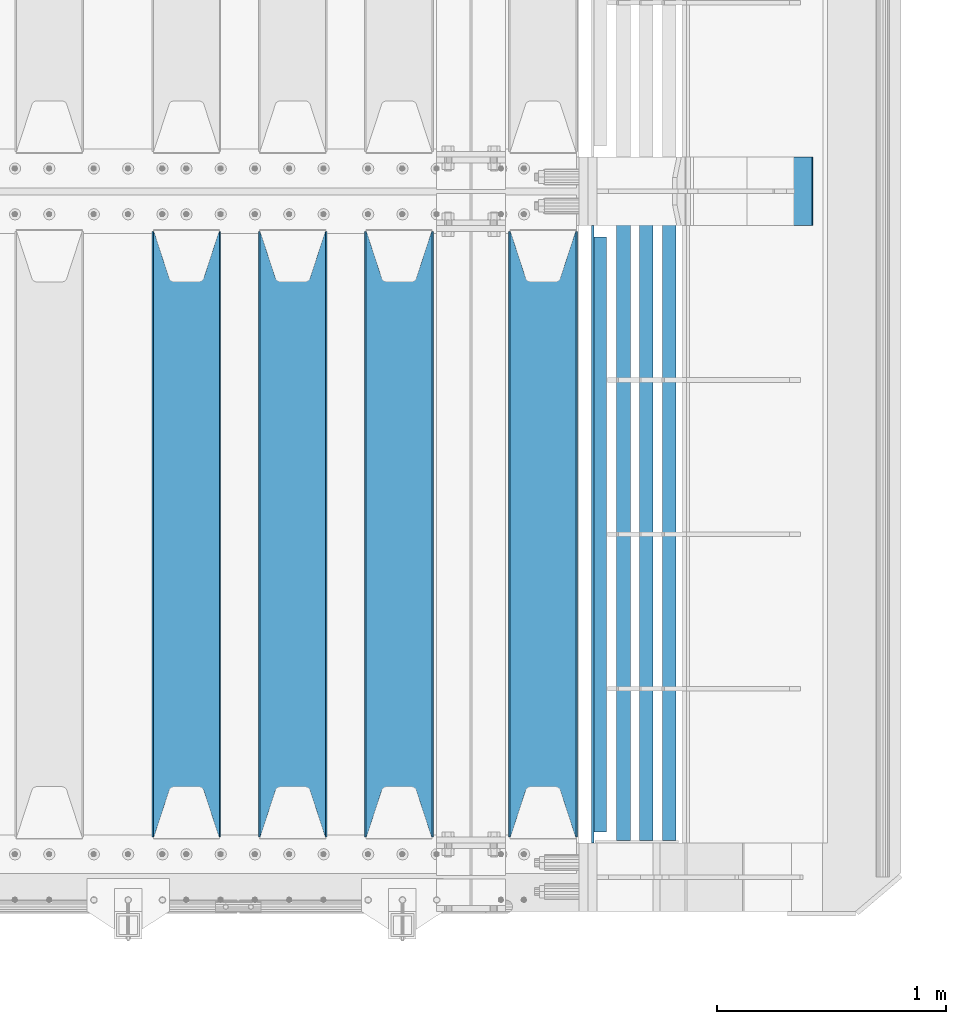
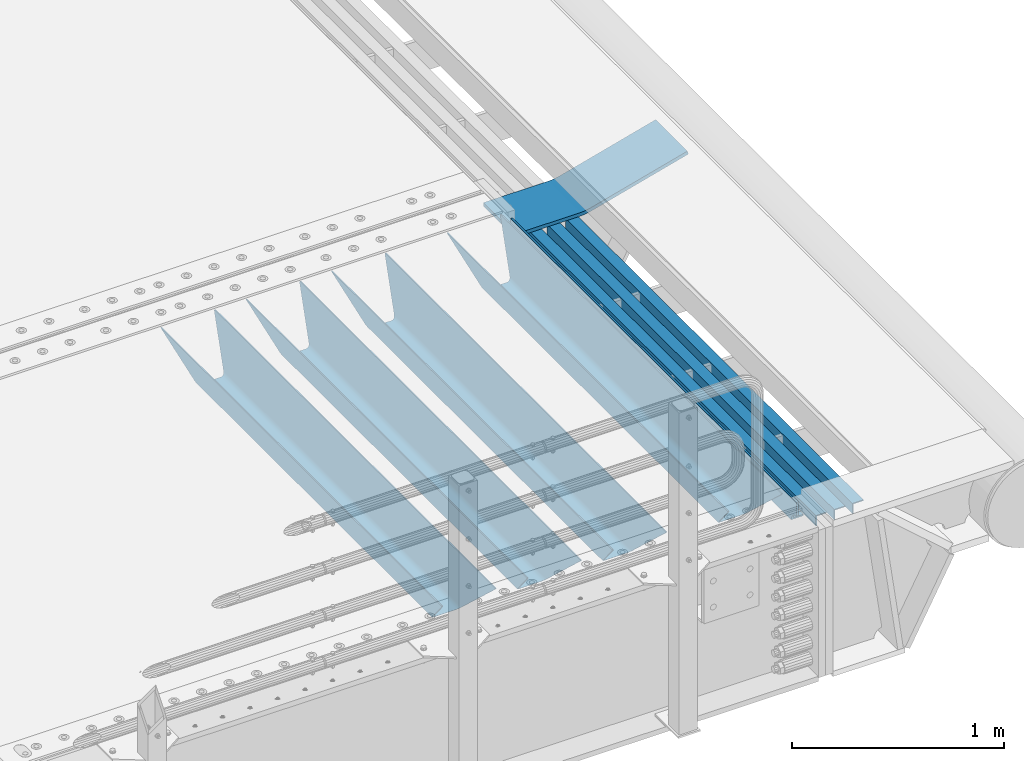
# One storey, part 130 of 257: 9 beams.
"""IFC2X3 building model written with IfcOpenShell, lengths in millimetres."""

from ifc_helpers import new_model, si_unit, frame, origin_with_axes, place, context, subcontext, project, spatial, faceted_brep, material, type_object, element, save


model = new_model("IFC2X3")

# Units and contexts
model_context = context("Model", 3, precision=1e-05, world=origin_with_axes())
body_context = subcontext(model_context, "Body", "Model", "MODEL_VIEW")
ifc_project = project(units=[si_unit("LENGTHUNIT", "METRE", prefix="MILLI"), si_unit("AREAUNIT", "SQUARE_METRE"), si_unit("VOLUMEUNIT", "CUBIC_METRE"), si_unit("MASSUNIT", "GRAM", prefix="KILO"), si_unit("TIMEUNIT", "SECOND"), si_unit("PLANEANGLEUNIT", "RADIAN"), si_unit("SOLIDANGLEUNIT", "STERADIAN"), si_unit("THERMODYNAMICTEMPERATUREUNIT", "DEGREE_CELSIUS"), si_unit("LUMINOUSINTENSITYUNIT", "LUMEN")], contexts=[model_context])

# Site, building, storey
site_placement = place(None, origin_with_axes())
site = spatial("IfcSite", under=ifc_project, at=site_placement, CompositionType="ELEMENT")
building_placement = place(site_placement, origin_with_axes())
building = spatial("IfcBuilding", under=site, at=building_placement, Name="Standard", CompositionType="ELEMENT")
storey_placement = place(building_placement, origin_with_axes())
storey = spatial("IfcBuildingStorey", under=building, at=storey_placement, Name="Undefined", CompositionType="ELEMENT", Elevation=0.0)

# Beams
ifc_material_1 = material(Name="STEEL/S355N")
beam_type_1 = type_object("IfcBeamType", PredefinedType="NOTDEFINED")
beam_1_placement = place(storey_placement, frame((59110.0, 175.0, -115.0), z_axis=(0.0, 0.0, 1.0), x_axis=(0.0, 1.0, 0.0)))
element("IfcBeam", 1, at=beam_1_placement, inside=storey, type_object=beam_type_1, material=ifc_material_1, context=body_context, shape_type="Brep", body=[
    faceted_brep([(0.0, 150.0, 115.0), (0.0, 143.690000000002, 115.0), (2650.00000000297, 143.690000000002, 115.0), (2650.00000000297, 150.0, 115.0), (2650.00000000297, 142.059565218406, 110.0000000031), (2650.00000000297, 148.369565218403, 110.0000000031), (2441.90079219208, -80.1103600731149, -98.0992078077845), (2437.7588105432, -77.5672621345584, -102.241189456673), (2434.06523489746, -74.4080125315522, -105.934765102404), (2430.91086095089, -70.7102721255724, -109.089139048974), (2428.37322971128, -66.5649389910031, -111.626770288588), (2426.51472138055, -62.0739139532889, -113.485278619323), (2425.38102192091, -57.3475956567636, -114.618978078955), (2424.99999999987, -52.5021667386536, -115.0), (2424.99999999987, 52.5021667386536, -115.0), (2425.38102192091, 57.3475956567636, -114.618978078955), (2426.51472138055, 62.0739139532889, -113.485278619323), (2428.37322971128, 66.5649389910031, -111.626770288588), (2430.91086095089, 70.7102721255724, -109.089139048974), (2434.06523489746, 74.4080125315522, -105.934765102404), (2437.7588105432, 77.5672621345584, -102.241189456673), (2441.90079219208, 80.1103600731149, -98.0992078077846), (2446.38936140511, 81.9747917625791, -93.6106385947584), (2448.24948500409, 76.2713538057287, -91.7505149957729), (2444.62967112262, 74.76777986261, -95.3703288772456), (2441.28936334126, 72.7168944282894, -98.710636658607), (2438.31067330438, 70.1691124903809, -101.689326695487), (2435.76682334747, 67.1870637758839, -104.233176652398), (2433.72034654133, 63.8440531834931, -106.279653458539), (2432.22154950041, 60.2222587982324, -107.778450499454), (2431.30727574265, 56.4107117849126, -108.692724257221), (2430.99999999987, 52.5031078186876, -109.0), (2430.99999999987, -52.5031078186876, -109.0), (2431.30727574265, -56.4107117849126, -108.692724257221), (2432.22154950041, -60.2222587982324, -107.778450499454), (2433.72034654133, -63.8440531834931, -106.279653458539), (2435.76682334747, -67.1870637758839, -104.233176652398), (2438.31067330438, -70.1691124903809, -101.689326695487), (2441.28936334126, -72.7168944282894, -98.7106366586071), (2444.62967112262, -74.76777986261, -95.3703288772457), (2448.24948500409, -76.2713538057287, -91.7505149957729), (2650.00000000297, -142.059565218406, 110.0000000031), (2650.00000000297, -148.369565218403, 110.0000000031), (2446.38936140511, -81.9747917625791, -93.6106385947584), (2650.00000000297, -143.690000000002, 115.0), (2650.00000000297, -150.0, 115.0), (0.0, -143.690000000002, 115.0), (0.0, -150.0, 115.0), (0.0, -148.369565218258, 110.000000002662), (203.61063859742, -81.9747917625791, -93.6106385947584), (208.099207810447, -80.1103600731149, -98.0992078077845), (212.241189459335, -77.5672621345584, -102.241189456673), (215.934765105066, -74.4080125315522, -105.934765102404), (219.089139051636, -70.7102721255724, -109.089139048974), (221.626770291251, -66.5649389910031, -111.626770288588), (223.485278621985, -62.0739139532889, -113.485278619323), (224.618978081617, -57.3475956567636, -114.618978078955), (225.000000002662, -52.5021667386536, -115.0), (225.000000002662, 52.5021667386536, -115.0), (224.618978081617, 57.3475956567636, -114.618978078955), (223.485278621985, 62.0739139532889, -113.485278619323), (221.626770291251, 66.5649389910031, -111.626770288588), (219.089139051636, 70.7102721255724, -109.089139048974), (215.934765105066, 74.4080125315522, -105.934765102404), (212.241189459335, 77.5672621345584, -102.241189456673), (208.099207810447, 80.1103600731149, -98.0992078077846), (203.61063859742, 81.9747917625791, -93.6106385947584), (0.0, 148.369565218258, 110.000000002662), (0.0, 142.05956521826, 110.000000002662), (201.750514998435, 76.2713538057287, -91.7505149957729), (205.370328879908, 74.76777986261, -95.3703288772456), (208.710636661269, 72.7168944282894, -98.710636658607), (211.689326698149, 70.1691124903809, -101.689326695487), (214.233176655061, 67.1870637758839, -104.233176652398), (216.279653461201, 63.8440531834931, -106.279653458539), (217.778450502116, 60.2222587982324, -107.778450499454), (218.692724259884, 56.4107117849126, -108.692724257221), (219.000000002662, 52.5031078186876, -109.0), (219.000000002662, -52.5031078186876, -109.0), (218.692724259884, -56.4107117849126, -108.692724257221), (217.778450502116, -60.2222587982324, -107.778450499454), (216.279653461201, -63.8440531834931, -106.279653458539), (214.233176655061, -67.1870637758839, -104.233176652398), (211.689326698149, -70.1691124903809, -101.689326695487), (208.710636661269, -72.7168944282894, -98.7106366586071), (205.370328879908, -74.76777986261, -95.3703288772457), (201.750514998435, -76.2713538057287, -91.7505149957729), (0.0, -142.05956521826, 110.000000002662)], [[[0, 1, 2, 3]], [[3, 2, 4, 5]], [[6, 7, 8, 9, 10, 11, 12, 13, 14, 15, 16, 17, 18, 19, 20, 21, 22, 5, 4, 23, 24, 25, 26, 27, 28, 29, 30, 31, 32, 33, 34, 35, 36, 37, 38, 39, 40, 41, 42, 43]], [[44, 45, 42, 41]], [[46, 47, 45, 44]], [[43, 42, 45, 47, 48, 49]], [[6, 43, 49, 50]], [[7, 6, 50, 51]], [[8, 7, 51, 52]], [[9, 8, 52, 53]], [[10, 9, 53, 54]], [[11, 10, 54, 55]], [[12, 11, 55, 56]], [[13, 12, 56, 57]], [[14, 13, 57, 58]], [[15, 14, 58, 59]], [[16, 15, 59, 60]], [[17, 16, 60, 61]], [[18, 17, 61, 62]], [[19, 18, 62, 63]], [[20, 19, 63, 64]], [[21, 20, 64, 65]], [[22, 21, 65, 66]], [[0, 3, 5, 22, 66, 67]], [[1, 0, 67, 68]], [[23, 4, 2, 1, 68, 69]], [[24, 23, 69, 70]], [[25, 24, 70, 71]], [[26, 25, 71, 72]], [[27, 26, 72, 73]], [[28, 27, 73, 74]], [[29, 28, 74, 75]], [[30, 29, 75, 76]], [[31, 30, 76, 77]], [[32, 31, 77, 78]], [[33, 32, 78, 79]], [[34, 33, 79, 80]], [[35, 34, 80, 81]], [[36, 35, 81, 82]], [[37, 36, 82, 83]], [[38, 37, 83, 84]], [[39, 38, 84, 85]], [[40, 39, 85, 86]], [[46, 44, 41, 40, 86, 87]], [[47, 46, 87, 48]], [[86, 85, 84, 83, 82, 81, 80, 79, 78, 77, 76, 75, 74, 73, 72, 71, 70, 69, 68, 67, 66, 65, 64, 63, 62, 61, 60, 59, 58, 57, 56, 55, 54, 53, 52, 51, 50, 49, 48, 87]]]),
])
beam_2_placement = place(storey_placement, frame((58480.0, 175.0, -115.0), z_axis=(0.0, 0.0, 1.0), x_axis=(0.0, 1.0, 0.0)))
element("IfcBeam", 2, at=beam_2_placement, inside=storey, type_object=beam_type_1, material=ifc_material_1, context=body_context, shape_type="Brep", body=[
    faceted_brep([(0.0, 150.0, 115.0), (0.0, 143.690000000002, 115.0), (2650.00000000297, 143.690000000002, 115.0), (2650.00000000297, 150.0, 115.0), (2650.00000000297, 142.059565218406, 110.0000000031), (2650.00000000297, 148.369565218403, 110.0000000031), (2441.90079219208, -80.1103600731149, -98.0992078077845), (2437.7588105432, -77.5672621345584, -102.241189456673), (2434.06523489746, -74.4080125315522, -105.934765102404), (2430.91086095089, -70.7102721255724, -109.089139048974), (2428.37322971128, -66.5649389910031, -111.626770288588), (2426.51472138055, -62.0739139532889, -113.485278619323), (2425.38102192091, -57.3475956567636, -114.618978078955), (2424.99999999987, -52.5021667386536, -115.0), (2424.99999999987, 52.5021667386536, -115.0), (2425.38102192091, 57.3475956567636, -114.618978078955), (2426.51472138055, 62.0739139532889, -113.485278619323), (2428.37322971128, 66.5649389910031, -111.626770288588), (2430.91086095089, 70.7102721255724, -109.089139048974), (2434.06523489746, 74.4080125315522, -105.934765102404), (2437.7588105432, 77.5672621345584, -102.241189456673), (2441.90079219208, 80.1103600731149, -98.0992078077846), (2446.38936140511, 81.9747917625791, -93.6106385947584), (2448.24948500409, 76.2713538057287, -91.7505149957729), (2444.62967112262, 74.76777986261, -95.3703288772456), (2441.28936334126, 72.7168944282894, -98.710636658607), (2438.31067330438, 70.1691124903809, -101.689326695487), (2435.76682334747, 67.1870637758839, -104.233176652398), (2433.72034654133, 63.8440531834931, -106.279653458539), (2432.22154950041, 60.2222587982324, -107.778450499454), (2431.30727574265, 56.4107117849126, -108.692724257221), (2430.99999999987, 52.5031078186876, -109.0), (2430.99999999987, -52.5031078186876, -109.0), (2431.30727574265, -56.4107117849126, -108.692724257221), (2432.22154950041, -60.2222587982324, -107.778450499454), (2433.72034654133, -63.8440531834931, -106.279653458539), (2435.76682334747, -67.1870637758839, -104.233176652398), (2438.31067330438, -70.1691124903809, -101.689326695487), (2441.28936334126, -72.7168944282894, -98.7106366586071), (2444.62967112262, -74.76777986261, -95.3703288772457), (2448.24948500409, -76.2713538057287, -91.7505149957729), (2650.00000000297, -142.059565218406, 110.0000000031), (2650.00000000297, -148.369565218403, 110.0000000031), (2446.38936140511, -81.9747917625791, -93.6106385947584), (2650.00000000297, -143.690000000002, 115.0), (2650.00000000297, -150.0, 115.0), (0.0, -143.690000000002, 115.0), (0.0, -150.0, 115.0), (0.0, -148.369565218258, 110.000000002662), (203.61063859742, -81.9747917625791, -93.6106385947584), (208.099207810447, -80.1103600731149, -98.0992078077845), (212.241189459335, -77.5672621345584, -102.241189456673), (215.934765105066, -74.4080125315522, -105.934765102404), (219.089139051636, -70.7102721255724, -109.089139048974), (221.626770291251, -66.5649389910031, -111.626770288588), (223.485278621985, -62.0739139532889, -113.485278619323), (224.618978081617, -57.3475956567636, -114.618978078955), (225.000000002662, -52.5021667386536, -115.0), (225.000000002662, 52.5021667386536, -115.0), (224.618978081617, 57.3475956567636, -114.618978078955), (223.485278621985, 62.0739139532889, -113.485278619323), (221.626770291251, 66.5649389910031, -111.626770288588), (219.089139051636, 70.7102721255724, -109.089139048974), (215.934765105066, 74.4080125315522, -105.934765102404), (212.241189459335, 77.5672621345584, -102.241189456673), (208.099207810447, 80.1103600731149, -98.0992078077846), (203.61063859742, 81.9747917625791, -93.6106385947584), (0.0, 148.369565218258, 110.000000002662), (0.0, 142.05956521826, 110.000000002662), (201.750514998435, 76.2713538057287, -91.7505149957729), (205.370328879908, 74.76777986261, -95.3703288772456), (208.710636661269, 72.7168944282894, -98.710636658607), (211.689326698149, 70.1691124903809, -101.689326695487), (214.233176655061, 67.1870637758839, -104.233176652398), (216.279653461201, 63.8440531834931, -106.279653458539), (217.778450502116, 60.2222587982324, -107.778450499454), (218.692724259884, 56.4107117849126, -108.692724257221), (219.000000002662, 52.5031078186876, -109.0), (219.000000002662, -52.5031078186876, -109.0), (218.692724259884, -56.4107117849126, -108.692724257221), (217.778450502116, -60.2222587982324, -107.778450499454), (216.279653461201, -63.8440531834931, -106.279653458539), (214.233176655061, -67.1870637758839, -104.233176652398), (211.689326698149, -70.1691124903809, -101.689326695487), (208.710636661269, -72.7168944282894, -98.7106366586071), (205.370328879908, -74.76777986261, -95.3703288772457), (201.750514998435, -76.2713538057287, -91.7505149957729), (0.0, -142.05956521826, 110.000000002662)], [[[0, 1, 2, 3]], [[3, 2, 4, 5]], [[6, 7, 8, 9, 10, 11, 12, 13, 14, 15, 16, 17, 18, 19, 20, 21, 22, 5, 4, 23, 24, 25, 26, 27, 28, 29, 30, 31, 32, 33, 34, 35, 36, 37, 38, 39, 40, 41, 42, 43]], [[44, 45, 42, 41]], [[46, 47, 45, 44]], [[43, 42, 45, 47, 48, 49]], [[6, 43, 49, 50]], [[7, 6, 50, 51]], [[8, 7, 51, 52]], [[9, 8, 52, 53]], [[10, 9, 53, 54]], [[11, 10, 54, 55]], [[12, 11, 55, 56]], [[13, 12, 56, 57]], [[14, 13, 57, 58]], [[15, 14, 58, 59]], [[16, 15, 59, 60]], [[17, 16, 60, 61]], [[18, 17, 61, 62]], [[19, 18, 62, 63]], [[20, 19, 63, 64]], [[21, 20, 64, 65]], [[22, 21, 65, 66]], [[0, 3, 5, 22, 66, 67]], [[1, 0, 67, 68]], [[23, 4, 2, 1, 68, 69]], [[24, 23, 69, 70]], [[25, 24, 70, 71]], [[26, 25, 71, 72]], [[27, 26, 72, 73]], [[28, 27, 73, 74]], [[29, 28, 74, 75]], [[30, 29, 75, 76]], [[31, 30, 76, 77]], [[32, 31, 77, 78]], [[33, 32, 78, 79]], [[34, 33, 79, 80]], [[35, 34, 80, 81]], [[36, 35, 81, 82]], [[37, 36, 82, 83]], [[38, 37, 83, 84]], [[39, 38, 84, 85]], [[40, 39, 85, 86]], [[46, 44, 41, 40, 86, 87]], [[47, 46, 87, 48]], [[86, 85, 84, 83, 82, 81, 80, 79, 78, 77, 76, 75, 74, 73, 72, 71, 70, 69, 68, 67, 66, 65, 64, 63, 62, 61, 60, 59, 58, 57, 56, 55, 54, 53, 52, 51, 50, 49, 48, 87]]]),
])
beam_3_placement = place(storey_placement, frame((58015.0, 175.0, -115.0), z_axis=(0.0, 0.0, 1.0), x_axis=(0.0, 1.0, 0.0)))
element("IfcBeam", 3, at=beam_3_placement, inside=storey, type_object=beam_type_1, material=ifc_material_1, context=body_context, shape_type="Brep", body=[
    faceted_brep([(0.0, 150.0, 115.0), (0.0, 143.690000000002, 115.0), (2650.00000000297, 143.690000000002, 115.0), (2650.00000000297, 150.0, 115.0), (2650.00000000297, 142.059565218406, 110.0000000031), (2650.00000000297, 148.369565218403, 110.0000000031), (2441.90079219208, -80.1103600731149, -98.0992078077845), (2437.7588105432, -77.5672621345584, -102.241189456673), (2434.06523489746, -74.4080125315522, -105.934765102404), (2430.91086095089, -70.7102721255724, -109.089139048974), (2428.37322971128, -66.5649389910031, -111.626770288588), (2426.51472138055, -62.0739139532889, -113.485278619323), (2425.38102192091, -57.3475956567636, -114.618978078955), (2424.99999999987, -52.5021667386536, -115.0), (2424.99999999987, 52.5021667386536, -115.0), (2425.38102192091, 57.3475956567636, -114.618978078955), (2426.51472138055, 62.0739139532889, -113.485278619323), (2428.37322971128, 66.5649389910031, -111.626770288588), (2430.91086095089, 70.7102721255724, -109.089139048974), (2434.06523489746, 74.4080125315522, -105.934765102404), (2437.7588105432, 77.5672621345584, -102.241189456673), (2441.90079219208, 80.1103600731149, -98.0992078077846), (2446.38936140511, 81.9747917625791, -93.6106385947584), (2448.24948500409, 76.2713538057287, -91.7505149957729), (2444.62967112262, 74.76777986261, -95.3703288772456), (2441.28936334126, 72.7168944282894, -98.710636658607), (2438.31067330438, 70.1691124903809, -101.689326695487), (2435.76682334747, 67.1870637758839, -104.233176652398), (2433.72034654133, 63.8440531834931, -106.279653458539), (2432.22154950041, 60.2222587982324, -107.778450499454), (2431.30727574265, 56.4107117849126, -108.692724257221), (2430.99999999987, 52.5031078186876, -109.0), (2430.99999999987, -52.5031078186876, -109.0), (2431.30727574265, -56.4107117849126, -108.692724257221), (2432.22154950041, -60.2222587982324, -107.778450499454), (2433.72034654133, -63.8440531834931, -106.279653458539), (2435.76682334747, -67.1870637758839, -104.233176652398), (2438.31067330438, -70.1691124903809, -101.689326695487), (2441.28936334126, -72.7168944282894, -98.7106366586071), (2444.62967112262, -74.76777986261, -95.3703288772457), (2448.24948500409, -76.2713538057287, -91.7505149957729), (2650.00000000297, -142.059565218406, 110.0000000031), (2650.00000000297, -148.369565218403, 110.0000000031), (2446.38936140511, -81.9747917625791, -93.6106385947584), (2650.00000000297, -143.690000000002, 115.0), (2650.00000000297, -150.0, 115.0), (0.0, -143.690000000002, 115.0), (0.0, -150.0, 115.0), (0.0, -148.369565218258, 110.000000002662), (203.61063859742, -81.9747917625791, -93.6106385947584), (208.099207810447, -80.1103600731149, -98.0992078077845), (212.241189459335, -77.5672621345584, -102.241189456673), (215.934765105066, -74.4080125315522, -105.934765102404), (219.089139051636, -70.7102721255724, -109.089139048974), (221.626770291251, -66.5649389910031, -111.626770288588), (223.485278621985, -62.0739139532889, -113.485278619323), (224.618978081617, -57.3475956567636, -114.618978078955), (225.000000002662, -52.5021667386536, -115.0), (225.000000002662, 52.5021667386536, -115.0), (224.618978081617, 57.3475956567636, -114.618978078955), (223.485278621985, 62.0739139532889, -113.485278619323), (221.626770291251, 66.5649389910031, -111.626770288588), (219.089139051636, 70.7102721255724, -109.089139048974), (215.934765105066, 74.4080125315522, -105.934765102404), (212.241189459335, 77.5672621345584, -102.241189456673), (208.099207810447, 80.1103600731149, -98.0992078077846), (203.61063859742, 81.9747917625791, -93.6106385947584), (0.0, 148.369565218258, 110.000000002662), (0.0, 142.05956521826, 110.000000002662), (201.750514998435, 76.2713538057287, -91.7505149957729), (205.370328879908, 74.76777986261, -95.3703288772456), (208.710636661269, 72.7168944282894, -98.710636658607), (211.689326698149, 70.1691124903809, -101.689326695487), (214.233176655061, 67.1870637758839, -104.233176652398), (216.279653461201, 63.8440531834931, -106.279653458539), (217.778450502116, 60.2222587982324, -107.778450499454), (218.692724259884, 56.4107117849126, -108.692724257221), (219.000000002662, 52.5031078186876, -109.0), (219.000000002662, -52.5031078186876, -109.0), (218.692724259884, -56.4107117849126, -108.692724257221), (217.778450502116, -60.2222587982324, -107.778450499454), (216.279653461201, -63.8440531834931, -106.279653458539), (214.233176655061, -67.1870637758839, -104.233176652398), (211.689326698149, -70.1691124903809, -101.689326695487), (208.710636661269, -72.7168944282894, -98.7106366586071), (205.370328879908, -74.76777986261, -95.3703288772457), (201.750514998435, -76.2713538057287, -91.7505149957729), (0.0, -142.05956521826, 110.000000002662)], [[[0, 1, 2, 3]], [[3, 2, 4, 5]], [[6, 7, 8, 9, 10, 11, 12, 13, 14, 15, 16, 17, 18, 19, 20, 21, 22, 5, 4, 23, 24, 25, 26, 27, 28, 29, 30, 31, 32, 33, 34, 35, 36, 37, 38, 39, 40, 41, 42, 43]], [[44, 45, 42, 41]], [[46, 47, 45, 44]], [[43, 42, 45, 47, 48, 49]], [[6, 43, 49, 50]], [[7, 6, 50, 51]], [[8, 7, 51, 52]], [[9, 8, 52, 53]], [[10, 9, 53, 54]], [[11, 10, 54, 55]], [[12, 11, 55, 56]], [[13, 12, 56, 57]], [[14, 13, 57, 58]], [[15, 14, 58, 59]], [[16, 15, 59, 60]], [[17, 16, 60, 61]], [[18, 17, 61, 62]], [[19, 18, 62, 63]], [[20, 19, 63, 64]], [[21, 20, 64, 65]], [[22, 21, 65, 66]], [[0, 3, 5, 22, 66, 67]], [[1, 0, 67, 68]], [[23, 4, 2, 1, 68, 69]], [[24, 23, 69, 70]], [[25, 24, 70, 71]], [[26, 25, 71, 72]], [[27, 26, 72, 73]], [[28, 27, 73, 74]], [[29, 28, 74, 75]], [[30, 29, 75, 76]], [[31, 30, 76, 77]], [[32, 31, 77, 78]], [[33, 32, 78, 79]], [[34, 33, 79, 80]], [[35, 34, 80, 81]], [[36, 35, 81, 82]], [[37, 36, 82, 83]], [[38, 37, 83, 84]], [[39, 38, 84, 85]], [[40, 39, 85, 86]], [[46, 44, 41, 40, 86, 87]], [[47, 46, 87, 48]], [[86, 85, 84, 83, 82, 81, 80, 79, 78, 77, 76, 75, 74, 73, 72, 71, 70, 69, 68, 67, 66, 65, 64, 63, 62, 61, 60, 59, 58, 57, 56, 55, 54, 53, 52, 51, 50, 49, 48, 87]]]),
])
beam_4_placement = place(storey_placement, frame((57550.0, 175.0, -115.0), z_axis=(0.0, 0.0, 1.0), x_axis=(0.0, 1.0, 0.0)))
element("IfcBeam", 4, at=beam_4_placement, inside=storey, type_object=beam_type_1, material=ifc_material_1, context=body_context, shape_type="Brep", body=[
    faceted_brep([(0.0, 150.0, 115.0), (0.0, 143.690000000002, 115.0), (2650.00000000297, 143.690000000002, 115.0), (2650.00000000297, 150.0, 115.0), (2650.00000000297, 142.059565218406, 110.0000000031), (2650.00000000297, 148.369565218403, 110.0000000031), (2441.90079219208, -80.1103600731149, -98.0992078077845), (2437.7588105432, -77.5672621345584, -102.241189456673), (2434.06523489746, -74.4080125315522, -105.934765102404), (2430.91086095089, -70.7102721255724, -109.089139048974), (2428.37322971128, -66.5649389910031, -111.626770288588), (2426.51472138055, -62.0739139532889, -113.485278619323), (2425.38102192091, -57.3475956567636, -114.618978078955), (2424.99999999987, -52.5021667386536, -115.0), (2424.99999999987, 52.5021667386536, -115.0), (2425.38102192091, 57.3475956567636, -114.618978078955), (2426.51472138055, 62.0739139532889, -113.485278619323), (2428.37322971128, 66.5649389910031, -111.626770288588), (2430.91086095089, 70.7102721255724, -109.089139048974), (2434.06523489746, 74.4080125315522, -105.934765102404), (2437.7588105432, 77.5672621345584, -102.241189456673), (2441.90079219208, 80.1103600731149, -98.0992078077846), (2446.38936140511, 81.9747917625791, -93.6106385947584), (2448.24948500409, 76.2713538057287, -91.7505149957729), (2444.62967112262, 74.76777986261, -95.3703288772456), (2441.28936334126, 72.7168944282894, -98.710636658607), (2438.31067330438, 70.1691124903809, -101.689326695487), (2435.76682334747, 67.1870637758839, -104.233176652398), (2433.72034654133, 63.8440531834931, -106.279653458539), (2432.22154950041, 60.2222587982324, -107.778450499454), (2431.30727574265, 56.4107117849126, -108.692724257221), (2430.99999999987, 52.5031078186876, -109.0), (2430.99999999987, -52.5031078186876, -109.0), (2431.30727574265, -56.4107117849126, -108.692724257221), (2432.22154950041, -60.2222587982324, -107.778450499454), (2433.72034654133, -63.8440531834931, -106.279653458539), (2435.76682334747, -67.1870637758839, -104.233176652398), (2438.31067330438, -70.1691124903809, -101.689326695487), (2441.28936334126, -72.7168944282894, -98.7106366586071), (2444.62967112262, -74.76777986261, -95.3703288772457), (2448.24948500409, -76.2713538057287, -91.7505149957729), (2650.00000000297, -142.059565218406, 110.0000000031), (2650.00000000297, -148.369565218403, 110.0000000031), (2446.38936140511, -81.9747917625791, -93.6106385947584), (2650.00000000297, -143.690000000002, 115.0), (2650.00000000297, -150.0, 115.0), (0.0, -143.690000000002, 115.0), (0.0, -150.0, 115.0), (0.0, -148.369565218258, 110.000000002662), (203.61063859742, -81.9747917625791, -93.6106385947584), (208.099207810447, -80.1103600731149, -98.0992078077845), (212.241189459335, -77.5672621345584, -102.241189456673), (215.934765105066, -74.4080125315522, -105.934765102404), (219.089139051636, -70.7102721255724, -109.089139048974), (221.626770291251, -66.5649389910031, -111.626770288588), (223.485278621985, -62.0739139532889, -113.485278619323), (224.618978081617, -57.3475956567636, -114.618978078955), (225.000000002662, -52.5021667386536, -115.0), (225.000000002662, 52.5021667386536, -115.0), (224.618978081617, 57.3475956567636, -114.618978078955), (223.485278621985, 62.0739139532889, -113.485278619323), (221.626770291251, 66.5649389910031, -111.626770288588), (219.089139051636, 70.7102721255724, -109.089139048974), (215.934765105066, 74.4080125315522, -105.934765102404), (212.241189459335, 77.5672621345584, -102.241189456673), (208.099207810447, 80.1103600731149, -98.0992078077846), (203.61063859742, 81.9747917625791, -93.6106385947584), (0.0, 148.369565218258, 110.000000002662), (0.0, 142.05956521826, 110.000000002662), (201.750514998435, 76.2713538057287, -91.7505149957729), (205.370328879908, 74.76777986261, -95.3703288772456), (208.710636661269, 72.7168944282894, -98.710636658607), (211.689326698149, 70.1691124903809, -101.689326695487), (214.233176655061, 67.1870637758839, -104.233176652398), (216.279653461201, 63.8440531834931, -106.279653458539), (217.778450502116, 60.2222587982324, -107.778450499454), (218.692724259884, 56.4107117849126, -108.692724257221), (219.000000002662, 52.5031078186876, -109.0), (219.000000002662, -52.5031078186876, -109.0), (218.692724259884, -56.4107117849126, -108.692724257221), (217.778450502116, -60.2222587982324, -107.778450499454), (216.279653461201, -63.8440531834931, -106.279653458539), (214.233176655061, -67.1870637758839, -104.233176652398), (211.689326698149, -70.1691124903809, -101.689326695487), (208.710636661269, -72.7168944282894, -98.7106366586071), (205.370328879908, -74.76777986261, -95.3703288772457), (201.750514998435, -76.2713538057287, -91.7505149957729), (0.0, -142.05956521826, 110.000000002662)], [[[0, 1, 2, 3]], [[3, 2, 4, 5]], [[6, 7, 8, 9, 10, 11, 12, 13, 14, 15, 16, 17, 18, 19, 20, 21, 22, 5, 4, 23, 24, 25, 26, 27, 28, 29, 30, 31, 32, 33, 34, 35, 36, 37, 38, 39, 40, 41, 42, 43]], [[44, 45, 42, 41]], [[46, 47, 45, 44]], [[43, 42, 45, 47, 48, 49]], [[6, 43, 49, 50]], [[7, 6, 50, 51]], [[8, 7, 51, 52]], [[9, 8, 52, 53]], [[10, 9, 53, 54]], [[11, 10, 54, 55]], [[12, 11, 55, 56]], [[13, 12, 56, 57]], [[14, 13, 57, 58]], [[15, 14, 58, 59]], [[16, 15, 59, 60]], [[17, 16, 60, 61]], [[18, 17, 61, 62]], [[19, 18, 62, 63]], [[20, 19, 63, 64]], [[21, 20, 64, 65]], [[22, 21, 65, 66]], [[0, 3, 5, 22, 66, 67]], [[1, 0, 67, 68]], [[23, 4, 2, 1, 68, 69]], [[24, 23, 69, 70]], [[25, 24, 70, 71]], [[26, 25, 71, 72]], [[27, 26, 72, 73]], [[28, 27, 73, 74]], [[29, 28, 74, 75]], [[30, 29, 75, 76]], [[31, 30, 76, 77]], [[32, 31, 77, 78]], [[33, 32, 78, 79]], [[34, 33, 79, 80]], [[35, 34, 80, 81]], [[36, 35, 81, 82]], [[37, 36, 82, 83]], [[38, 37, 83, 84]], [[39, 38, 84, 85]], [[40, 39, 85, 86]], [[46, 44, 41, 40, 86, 87]], [[47, 46, 87, 48]], [[86, 85, 84, 83, 82, 81, 80, 79, 78, 77, 76, 75, 74, 73, 72, 71, 70, 69, 68, 67, 66, 65, 64, 63, 62, 61, 60, 59, 58, 57, 56, 55, 54, 53, 52, 51, 50, 49, 48, 87]]]),
])
ifc_material_2 = material(Name="STEEL/S355J2")
beam_type_2 = type_object("IfcBeamType", PredefinedType="NOTDEFINED")
beam_5_placement = place(storey_placement, frame((59354.5025260065, 150.0, -124.999999999968), z_axis=(0.0, 0.0, 1.0), x_axis=(0.0, 1.0, 0.0)))
element("IfcBeam", 5, at=beam_5_placement, inside=storey, type_object=beam_type_2, material=ifc_material_2, context=body_context, shape_type="Brep", body=[
    faceted_brep([(2700.0, 22.5, -15.0), (2684.54915028125, 22.5, -17.4471741852423), (2684.54915028125, 32.5, -17.4471741852423), (2700.0, 32.5, -15.0), (2670.61073738538, 22.5, -24.5491502812526), (2670.61073738538, 32.5, -24.5491502812526), (2659.54915028125, 22.5, -35.6107373853764), (2659.54915028125, 32.5, -35.6107373853764), (2652.44717418524, 22.5, -49.5491502812526), (2652.44717418524, 32.5, -49.5491502812526), (2651.58384440325, -32.5, -55.0), (2650.0, -32.5, -65.0), (2650.0, 32.5, -65.0), (2651.58384440325, 22.5, -55.0), (0.0, 32.5, 65.0), (0.0, 22.5, 65.0), (2700.0, 22.5, 65.0), (2700.0, 32.5, 65.0), (0.0, 32.5, -15.0), (0.0, 22.5, -15.0), (15.4508497187474, 32.5, -17.4471741852423), (15.4508497187474, 22.5, -17.4471741852423), (29.3892626146236, 32.5, -24.5491502812526), (29.3892626146236, 22.5, -24.5491502812526), (40.4508497187473, 32.5, -35.6107373853763), (40.4508497187473, 22.5, -35.6107373853763), (47.5528258147577, 32.5, -49.5491502812526), (47.5528258147577, 22.5, -49.5491502812526), (50.0, -32.5, -65.0), (48.4161555967548, -32.5, -55.0), (48.4161555967548, 22.5, -55.0), (50.0, 32.5, -65.0)], [[[0, 1, 2, 3]], [[4, 5, 2, 1]], [[6, 7, 5, 4]], [[8, 9, 7, 6]], [[10, 11, 12, 9, 8, 13]], [[14, 15, 16, 17]], [[15, 14, 18, 19]], [[19, 18, 20, 21]], [[21, 20, 22, 23]], [[23, 22, 24, 25]], [[25, 24, 26, 27]], [[28, 29, 30, 27, 26, 31]], [[30, 29, 10, 13]], [[16, 15, 19, 21, 23, 25, 27, 30, 13, 8, 6, 4, 1, 0]], [[17, 16, 0, 3]], [[5, 7, 9, 12, 31, 26, 24, 22, 20, 18, 14, 17, 3, 2]], [[28, 31, 12, 11]], [[29, 28, 11, 10]]]),
])
beam_type_3 = type_object("IfcBeamType", PredefinedType="NOTDEFINED")
beam_6_placement = place(storey_placement, frame((59346.9988298908, 3000.0, -169.999999999995), z_axis=(0.0, -1.0, 0.0), x_axis=(1.0, 0.0, 0.0)))
element("IfcBeam", 6, at=beam_6_placement, inside=storey, type_object=beam_type_3, material=ifc_material_1, context=body_context, shape_type="Brep", body=[
    faceted_brep([(0.0, 10.0, -150.0), (0.0, 10.0, 150.0), (356.495387467709, 10.0, 150.0), (356.495387467709, 10.0000000000045, -150.0), (0.0, -10.0, 150.0), (0.0, -10.0, -150.0), (356.495387467709, -10.0, -150.0), (356.495387467709, -10.0, 150.0), (382.770279632619, 11.7334369042663, 150.0), (382.770279632619, 11.7334369042663, -150.0), (385.397768849085, -8.09321940530714, -150.0), (385.397768849085, -8.09321940530714, 150.0), (413.799145685371, -2.4059304593832, -150.0), (413.799145685371, -2.4059304593832, 150.0), (408.589713120156, 16.9036995823731, 150.0), (408.589713119858, 16.9036995827009, -150.0), (938.999999999978, 160.0, 150.0), (938.999999999978, 160.0, -150.0), (944.209432565192, 140.69036995827, 150.0), (944.209432565192, 140.69036995827, -150.0)], [[[0, 1, 2, 3]], [[4, 5, 6, 7]], [[5, 4, 1, 0]], [[3, 2, 8, 9]], [[7, 6, 10, 11]], [[10, 12, 13, 11]], [[8, 14, 15, 9]], [[15, 14, 16, 17]], [[14, 8, 2, 1, 4, 7, 11, 13, 18, 16]], [[13, 12, 19, 18]], [[12, 10, 6, 5, 0, 3, 9, 15, 17, 19]], [[18, 19, 17, 16]]]),
])
beam_type_4 = type_object("IfcBeamType", PredefinedType="NOTDEFINED")
for number, where, z_axis, x_axis in (
    (7, (59662.0024147167, 2869.99999765908, -210.000211453656), (0.0, 0.0, -1.0), (0.0, -1.0, 0.0)),
    (8, (59562.0024147167, 2869.99999765908, -210.000211453656), (0.0, 0.0, -1.0), (0.0, -1.0, 0.0)),
    (9, (59462.002414716, 2869.99999765908, -210.000211453712), (0.0, 0.0, -1.0), (0.0, -1.0, 0.0)),
):
    element("IfcBeam", number, at=place(storey_placement, frame(where, z_axis=z_axis, x_axis=x_axis)), inside=storey, type_object=beam_type_4, material=ifc_material_2, context=body_context, shape_type="Brep", body=[
        faceted_brep([(-9.09494701772928e-13, 29.9999999999854, -29.9999999999999), (-9.09494701772928e-13, 29.9999999999854, 30.0000000000001), (2710.00000000001, 30.0, 30.0000000000001), (2710.00000000001, 29.9999999999927, -30.0), (-9.09494701772928e-13, 23.9999999999854, 30.0), (2710.00000000001, 24.0, 30.0), (-1.81898940354586e-12, 23.9999999999854, -24.0), (2710.00000000001, 23.9999999999927, -24.0), (-1.81898940354586e-12, -30.0000000000146, -24.0), (2710.00000000001, -30.0000000000073, -24.0), (-1.81898940354586e-12, -30.0000000000146, -30.0), (2710.00000000001, -30.0000000000073, -30.0)], [[[0, 1, 2, 3]], [[1, 4, 5, 2]], [[4, 6, 7, 5]], [[6, 8, 9, 7]], [[8, 10, 11, 9]], [[10, 0, 3, 11]], [[5, 7, 9, 11, 3, 2]], [[10, 8, 6, 4, 1, 0]]]),
    ])

save(model, "model.ifc")
